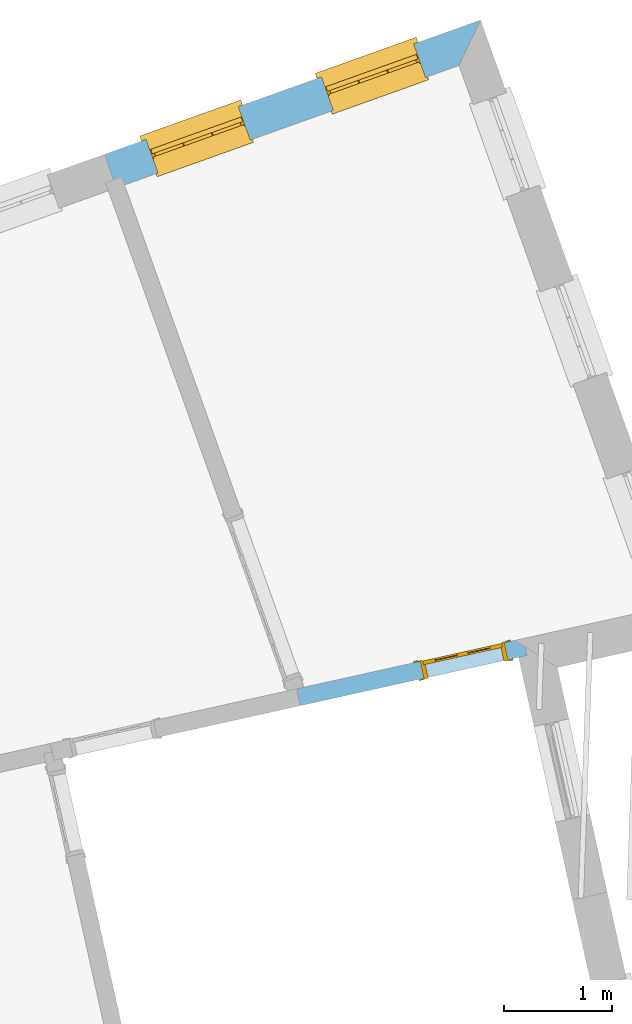
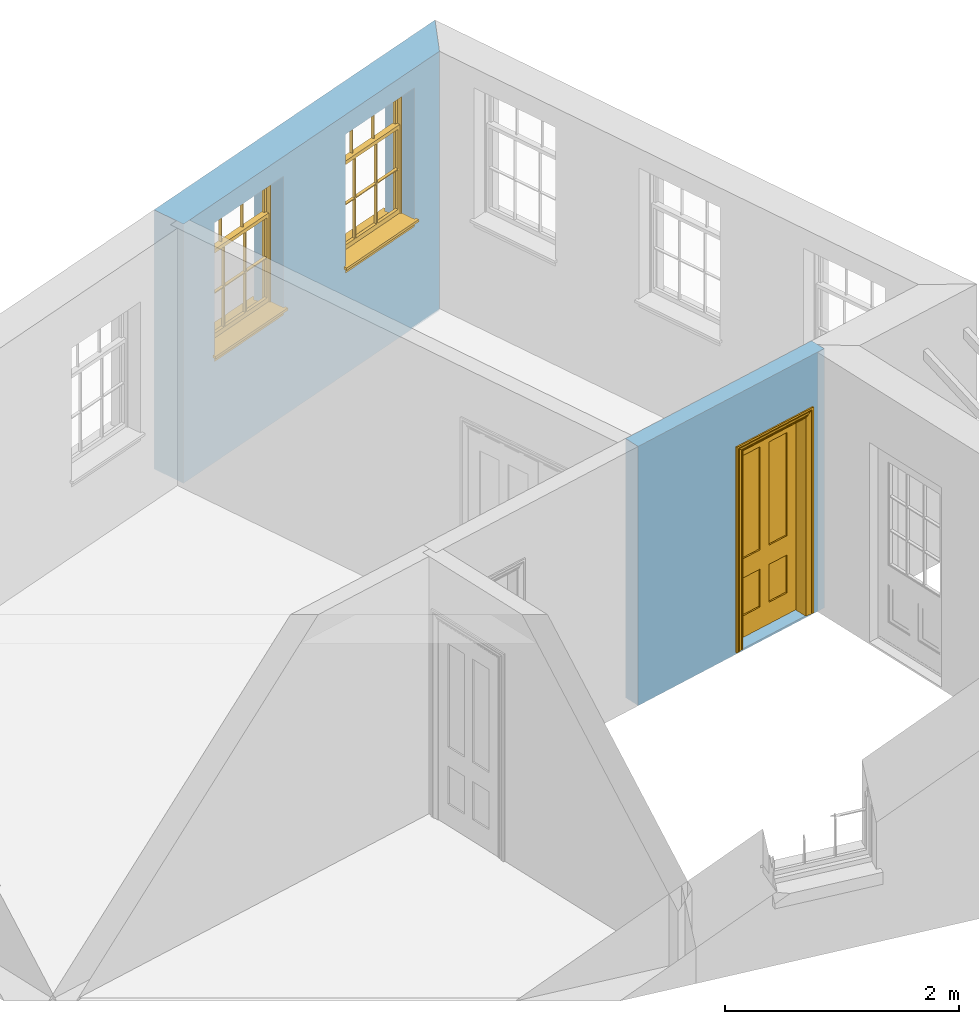
# One storey, part 8 of 11: 2 windows, 1 door, 3 openings, plus 2 elements that do not belong to this part.
"""IFC2X3 building model written with IfcOpenShell, lengths in metres."""

from ifc_helpers import new_model, si_unit, frame, origin, place, context, subcontext, project, spatial, polyline, outline, extrude, faceted_brep, material, layer, layer_set, layer_usage, element, fill, save


model = new_model("IFC2X3")

# Units and contexts
model_context = context("Model", 3, world=origin())
body_context = subcontext(model_context, "Body", "Model", "MODEL_VIEW")
ifc_project = project(units=[si_unit("PLANEANGLEUNIT", "RADIAN"), si_unit("MASSUNIT", "GRAM", prefix="KILO"), si_unit("FORCEUNIT", "NEWTON", prefix="KILO"), si_unit("LENGTHUNIT", "METRE")], contexts=[model_context])

# Site, building, storey
site_placement = place(None, origin())
site = spatial("IfcSite", under=ifc_project, at=site_placement, CompositionType="ELEMENT")
building_placement = place(None, origin())
building = spatial("IfcBuilding", under=site, at=building_placement, Name="Building plot-16", CompositionType="ELEMENT")
storey_placement = place(None, frame((0.0, 0.0, 9.0)))
storey = spatial("IfcBuildingStorey", under=building, at=storey_placement, Name="Floor 2", CompositionType="ELEMENT", Elevation=9.0)

# Wall, openings, windows
ifc_material_1 = material(Name="Masonry")
ifc_layer_1 = layer(ifc_material_1, 0.33, ventilated=False)
ifc_layer_set_1 = layer_set([ifc_layer_1], Name="My Wall")
ifc_layer_usage_1 = layer_usage(ifc_layer_set_1, "AXIS2", "NEGATIVE", 0.08)
wall_1_placement = place(storey_placement, origin())
wall_1 = element("IfcWallStandardCase", 1, at=wall_1_placement, inside=storey, material=ifc_layer_usage_1, Name="exterior", context=body_context, shape_type="SweptSolid", body=[
    extrude(outline(polyline([(95.5770005534573, 40.8505427478087), (95.7767041340643, 41.2723465883469), (92.2893042146699, 40.0260985111248), (92.4003543446355, 39.7153448005522), (95.5770005534573, 40.8505427478087)])), origin(), (0.0, 0.0, 1.0), 2.7),
])
opening_1_placement = place(storey_placement, frame((0.0, 0.0, 1.05)))
opening_1 = element("IfcOpeningElement", 2, at=opening_1_placement, cuts=wall_1, Name="Opening", ObjectType="Opening", context=body_context, shape_type="SweptSolid", body=[
    extrude(outline(polyline([(95.1567529953617, 41.0508024774225), (94.29982609651, 40.7445733311538), (94.4108762264756, 40.4338196205812), (95.2678031253273, 40.74004876685), (95.1567529953617, 41.0508024774225)])), origin(), (0.0, 0.0, 1.0), 1.445),
])
opening_2_placement = place(storey_placement, frame((0.0, 0.0, 1.05)))
opening_2 = element("IfcOpeningElement", 3, at=opening_2_placement, cuts=wall_1, Name="Opening", ObjectType="Opening", context=body_context, shape_type="SweptSolid", body=[
    extrude(outline(polyline([(93.5307627745177, 40.4697428819803), (92.6738358756661, 40.1635137357116), (92.7848860056317, 39.852760025139), (93.6418129044833, 40.1589891714077), (93.5307627745177, 40.4697428819803)])), origin(), (0.0, 0.0, 1.0), 1.445),
])
window_1_placement = place(storey_placement, frame((95.2408818816993, 40.815382999716, 1.05), z_axis=(0.0, 0.0, 1.0), x_axis=(-0.856926898851654, -0.30622914626872, 0.0)))
window_1 = element("IfcWindow", 4, at=window_1_placement, inside=storey, Name="kitchen outside window", OverallHeight=1.445, OverallWidth=0.91, context=body_context, shape_type="Brep", held_by="IfcProductRepresentation", body=[
    faceted_brep([(0.876875, -0.105, 0.999097), (0.876875, -0.105, 1.411875), (0.9, -0.105, 1.435), (0.033125, -0.105, 1.411875), (0.033125, -0.105, 0.999097), (0.01, -0.105, 1.435), (0.033125, -0.135, 1.411875), (0.01, -0.135, 1.435), (0.033125, -0.135, 0.999097), (0.876875, -0.135, 1.411875), (0.876875, -0.135, 0.999097), (0.9, -0.135, 1.435), (0.033125, -0.105, 0.960972), (0.01, -0.105, 0.960972), (0.033125, -0.105, 0.548195), (0.876875, -0.105, 0.960972), (0.876875, -0.105, 0.548195), (0.9, -0.105, 0.960972), (0.876875, -0.105, 0.538195), (0.876875, -0.105, 0.125417), (0.9, -0.105, 0.077167), (0.033125, -0.105, 0.125417), (0.033125, -0.105, 0.538195), (0.01, -0.105, 0.077167), (0.9, -0.135, 0.960972), (0.01, -0.135, 0.960972), (-0.0425, -0.25, 0.01), (-0.0425, -0.3, 0.001667), (0.0, -0.25, 0.01), (0.9525, -0.25, 0.01), (0.91, -0.25, 0.01), (0.9525, -0.3, 0.001667), (-0.02, 0.08, 0.077167), (0.0, 0.08, 0.077167), (-0.02, 0.11, 0.077167), (0.0, -0.06, 0.077167), (0.01, -0.06, 0.077167), (0.91, -0.06, 0.077167), (0.91, 0.08, 0.077167), (0.9, -0.06, 0.077167), (0.93, 0.08, 0.077167), (0.93, 0.11, 0.077167), (0.01, -0.105, 0.999097), (0.01, -0.075, 0.999097), (0.9, -0.105, 0.999097), (0.9, -0.075, 0.999097), (0.876875, -0.075, 0.125417), (0.876875, -0.075, 0.538195), (0.9, -0.075, 0.077167), (0.876875, -0.075, 0.548195), (0.876875, -0.075, 0.960972), (0.033125, -0.075, 0.125417), (0.01, -0.075, 0.077167), (0.033125, -0.075, 0.538195), (0.033125, -0.075, 0.960972), (0.033125, -0.075, 0.548195), (-0.02, 0.08, 0.052167), (-0.02, 0.11, 0.052167), (0.93, 0.11, 0.052167), (0.93, 0.08, 0.052167), (0.91, 0.08, 0.052167), (0.0, 0.08, 0.052167), (0.91, -0.15, 0.026667), (0.0, -0.15, 0.026667), (-0.0425, -0.3, -0.123333), (0.9525, -0.3, -0.123333), (-0.0425, -0.25, -0.123333), (0.9525, -0.25, -0.123333), (0.01, -0.06, 1.435), (0.9, -0.06, 1.435), (0.0, -0.06, 1.445), (0.91, -0.06, 1.445), (0.01, -0.15, 0.077167), (0.9, -0.15, 0.077167), (0.592292, -0.105, 0.125417), (0.592292, -0.075, 0.125417), (0.317708, -0.075, 0.125417), (0.317708, -0.105, 0.125417), (0.592292, -0.105, 0.548195), (0.317708, -0.105, 0.548195), (0.317708, -0.105, 0.538195), (0.592292, -0.105, 0.538195), (0.592292, -0.075, 0.548195), (0.317708, -0.075, 0.548195), (0.602292, -0.075, 0.548195), (0.602292, -0.105, 0.548195), (0.317708, -0.075, 0.538195), (0.307708, -0.075, 0.125417), (0.307708, -0.075, 0.538195), (0.602292, -0.075, 0.538195), (0.602292, -0.075, 0.125417), (0.592292, -0.075, 0.538195), (0.307708, -0.075, 0.548195), (0.317708, -0.075, 0.960972), (0.307708, -0.075, 0.960972), (0.602292, -0.075, 0.960972), (0.592292, -0.075, 0.960972), (0.307708, -0.105, 0.538195), (0.307708, -0.105, 0.125417), (0.307708, -0.105, 0.548195), (0.307708, -0.105, 0.960972), (0.592292, -0.105, 0.960972), (0.317708, -0.105, 0.960972), (0.602292, -0.105, 0.960972), (0.602292, -0.105, 0.538195), (0.602292, -0.105, 0.125417), (0.317708, -0.135, 1.411875), (0.307708, -0.135, 1.411875), (0.307708, -0.135, 0.999097), (0.317708, -0.135, 0.999097), (0.602292, -0.135, 1.411875), (0.592292, -0.135, 1.411875), (0.592292, -0.135, 0.999097), (0.602292, -0.135, 0.999097), (0.317708, -0.105, 0.999097), (0.307708, -0.105, 0.999097), (0.307708, -0.105, 1.411875), (0.317708, -0.105, 1.411875), (0.602292, -0.105, 0.999097), (0.592292, -0.105, 0.999097), (0.592292, -0.105, 1.411875), (0.602292, -0.105, 1.411875), (0.91, -0.15, 1.445), (0.9, -0.15, 1.435), (0.01, -0.15, 1.435), (0.0, -0.15, 1.445), (0.91, -0.25, 0.0), (0.0, -0.25, 0.0), (0.91, 0.08, 0.0), (0.0, 0.08, 0.0)], [[[0, 1, 2]], [[3, 4, 5]], [[6, 7, 8]], [[9, 10, 11]], [[12, 13, 14]], [[15, 16, 17]], [[18, 19, 20]], [[21, 22, 23]], [[24, 15, 17]], [[13, 12, 25]], [[26, 27, 28]], [[29, 30, 31]], [[32, 33, 34]], [[35, 36, 33]], [[37, 38, 39]], [[40, 41, 38]], [[42, 4, 43]], [[44, 45, 0]], [[46, 47, 48]], [[49, 50, 45]], [[51, 52, 53]], [[54, 55, 43]], [[38, 33, 36, 39]], [[41, 34, 33, 38]], [[56, 32, 34, 57]], [[57, 34, 41, 58]], [[58, 41, 40, 59]], [[57, 58, 60, 61]], [[52, 48, 39, 36]], [[62, 63, 28, 30]], [[27, 31, 30, 28]], [[27, 64, 65, 31]], [[66, 67, 65, 64]], [[2, 5, 68, 69]], [[68, 70, 71, 69]], [[20, 23, 72, 73]], [[73, 72, 63, 62]], [[74, 75, 76, 77]], [[78, 79, 80, 81]], [[78, 82, 83, 79]], [[16, 49, 84, 85]], [[86, 76, 87, 88]], [[89, 90, 75, 91]], [[92, 88, 53, 55]], [[82, 91, 86, 83]], [[93, 83, 92, 94]], [[95, 84, 82, 96]], [[89, 84, 49, 47]], [[97, 88, 87, 98]], [[22, 53, 88, 97]], [[81, 91, 75, 74]], [[80, 86, 91, 81]], [[77, 76, 86, 80]], [[99, 92, 55, 14]], [[100, 94, 92, 99]], [[101, 96, 82, 78]], [[79, 83, 93, 102]], [[85, 84, 95, 103]], [[104, 89, 47, 18]], [[105, 90, 89, 104]], [[104, 18, 16, 85]], [[80, 97, 98, 77]], [[104, 81, 74, 105]], [[103, 101, 78, 85]], [[99, 14, 22, 97]], [[102, 100, 99, 79]], [[106, 107, 108, 109]], [[110, 111, 112, 113]], [[114, 115, 116, 117]], [[118, 119, 120, 121]], [[107, 116, 115, 108]], [[111, 120, 119, 112]], [[109, 114, 117, 106]], [[113, 118, 121, 110]], [[85, 78, 81, 104]], [[84, 89, 91, 82]], [[83, 86, 88, 92]], [[79, 99, 97, 80]], [[109, 112, 119, 114]], [[102, 93, 96, 101]], [[106, 117, 120, 111]], [[98, 87, 51, 21]], [[6, 3, 116, 107]], [[110, 121, 1, 9]], [[19, 46, 90, 105]], [[26, 66, 64, 27]], [[29, 31, 65, 67]], [[25, 24, 112, 109]], [[11, 7, 106, 111]], [[75, 48, 52, 76]], [[43, 45, 96, 93]], [[45, 43, 114, 119]], [[5, 2, 120, 117]], [[24, 25, 102, 101]], [[42, 5, 4]], [[2, 44, 0]], [[49, 45, 48, 47]], [[52, 43, 55, 53]], [[14, 13, 23, 22]], [[20, 17, 16, 18]], [[24, 11, 10]], [[25, 8, 7]], [[8, 4, 3, 6]], [[9, 1, 0, 10]], [[15, 50, 49, 16]], [[18, 47, 46, 19]], [[21, 51, 53, 22]], [[14, 55, 54, 12]], [[44, 2, 69, 45]], [[68, 5, 42, 43]], [[36, 35, 70, 68]], [[39, 69, 71, 37]], [[62, 122, 123, 73]], [[63, 72, 124, 125]], [[8, 108, 115, 4]], [[113, 10, 0, 118]], [[94, 100, 12, 54]], [[17, 20, 73, 24]], [[72, 23, 13, 25]], [[52, 36, 68, 43]], [[69, 39, 48, 45]], [[11, 24, 73, 123]], [[7, 124, 72, 25]], [[23, 77, 98]], [[98, 21, 23]], [[105, 74, 20]], [[20, 19, 105]], [[20, 74, 77, 23]], [[113, 112, 24]], [[24, 10, 113]], [[25, 109, 108]], [[108, 8, 25]], [[110, 9, 11]], [[11, 111, 110]], [[7, 6, 107]], [[107, 106, 7]], [[5, 117, 116]], [[116, 3, 5]], [[121, 120, 2]], [[2, 1, 121]], [[11, 123, 124, 7]], [[122, 125, 124, 123]], [[43, 93, 94]], [[94, 54, 43]], [[96, 45, 95]], [[50, 95, 45]], [[15, 103, 95, 50]], [[48, 75, 90]], [[90, 46, 48]], [[87, 76, 52]], [[52, 51, 87]], [[103, 15, 24]], [[24, 101, 103]], [[100, 102, 25]], [[25, 12, 100]], [[115, 114, 43]], [[43, 4, 115]], [[118, 0, 45]], [[45, 119, 118]], [[71, 70, 125, 122]], [[70, 35, 63, 125]], [[122, 62, 37, 71]], [[126, 67, 66, 127]], [[60, 58, 59]], [[38, 60, 59, 40]], [[61, 56, 57]], [[32, 56, 61, 33]], [[61, 60, 128, 129]], [[62, 60, 38, 37]], [[126, 128, 60, 62]], [[33, 61, 63, 35]], [[61, 129, 127, 63]], [[128, 126, 127, 129]], [[28, 127, 66, 26]], [[63, 127, 28]], [[29, 67, 126, 30]], [[30, 126, 62]]]),
])
fill(opening_1, window_1)
window_2_placement = place(storey_placement, frame((93.6148916608553, 40.2343234042738, 1.05), z_axis=(0.0, 0.0, 1.0), x_axis=(-0.856926898851654, -0.30622914626872, 0.0)))
window_2 = element("IfcWindow", 5, at=window_2_placement, inside=storey, Name="kitchen outside window", OverallHeight=1.445, OverallWidth=0.91, context=body_context, shape_type="Brep", held_by="IfcProductRepresentation", body=[
    faceted_brep([(0.876875, -0.105, 0.999097), (0.876875, -0.105, 1.411875), (0.9, -0.105, 1.435), (0.033125, -0.105, 1.411875), (0.033125, -0.105, 0.999097), (0.01, -0.105, 1.435), (0.033125, -0.135, 1.411875), (0.01, -0.135, 1.435), (0.033125, -0.135, 0.999097), (0.876875, -0.135, 1.411875), (0.876875, -0.135, 0.999097), (0.9, -0.135, 1.435), (0.033125, -0.105, 0.960972), (0.01, -0.105, 0.960972), (0.033125, -0.105, 0.548195), (0.876875, -0.105, 0.960972), (0.876875, -0.105, 0.548195), (0.9, -0.105, 0.960972), (0.876875, -0.105, 0.538195), (0.876875, -0.105, 0.125417), (0.9, -0.105, 0.077167), (0.033125, -0.105, 0.125417), (0.033125, -0.105, 0.538195), (0.01, -0.105, 0.077167), (0.9, -0.135, 0.960972), (0.01, -0.135, 0.960972), (-0.0425, -0.25, 0.01), (-0.0425, -0.3, 0.001667), (0.0, -0.25, 0.01), (0.9525, -0.25, 0.01), (0.91, -0.25, 0.01), (0.9525, -0.3, 0.001667), (-0.02, 0.08, 0.077167), (0.0, 0.08, 0.077167), (-0.02, 0.11, 0.077167), (0.0, -0.06, 0.077167), (0.01, -0.06, 0.077167), (0.91, -0.06, 0.077167), (0.91, 0.08, 0.077167), (0.9, -0.06, 0.077167), (0.93, 0.08, 0.077167), (0.93, 0.11, 0.077167), (0.01, -0.105, 0.999097), (0.01, -0.075, 0.999097), (0.9, -0.105, 0.999097), (0.9, -0.075, 0.999097), (0.876875, -0.075, 0.125417), (0.876875, -0.075, 0.538195), (0.9, -0.075, 0.077167), (0.876875, -0.075, 0.548195), (0.876875, -0.075, 0.960972), (0.033125, -0.075, 0.125417), (0.01, -0.075, 0.077167), (0.033125, -0.075, 0.538195), (0.033125, -0.075, 0.960972), (0.033125, -0.075, 0.548195), (-0.02, 0.08, 0.052167), (-0.02, 0.11, 0.052167), (0.93, 0.11, 0.052167), (0.93, 0.08, 0.052167), (0.91, 0.08, 0.052167), (0.0, 0.08, 0.052167), (0.91, -0.15, 0.026667), (0.0, -0.15, 0.026667), (-0.0425, -0.3, -0.123333), (0.9525, -0.3, -0.123333), (-0.0425, -0.25, -0.123333), (0.9525, -0.25, -0.123333), (0.01, -0.06, 1.435), (0.9, -0.06, 1.435), (0.0, -0.06, 1.445), (0.91, -0.06, 1.445), (0.01, -0.15, 0.077167), (0.9, -0.15, 0.077167), (0.592292, -0.105, 0.125417), (0.592292, -0.075, 0.125417), (0.317708, -0.075, 0.125417), (0.317708, -0.105, 0.125417), (0.592292, -0.105, 0.548195), (0.317708, -0.105, 0.548195), (0.317708, -0.105, 0.538195), (0.592292, -0.105, 0.538195), (0.592292, -0.075, 0.548195), (0.317708, -0.075, 0.548195), (0.602292, -0.075, 0.548195), (0.602292, -0.105, 0.548195), (0.317708, -0.075, 0.538195), (0.307708, -0.075, 0.125417), (0.307708, -0.075, 0.538195), (0.602292, -0.075, 0.538195), (0.602292, -0.075, 0.125417), (0.592292, -0.075, 0.538195), (0.307708, -0.075, 0.548195), (0.317708, -0.075, 0.960972), (0.307708, -0.075, 0.960972), (0.602292, -0.075, 0.960972), (0.592292, -0.075, 0.960972), (0.307708, -0.105, 0.538195), (0.307708, -0.105, 0.125417), (0.307708, -0.105, 0.548195), (0.307708, -0.105, 0.960972), (0.592292, -0.105, 0.960972), (0.317708, -0.105, 0.960972), (0.602292, -0.105, 0.960972), (0.602292, -0.105, 0.538195), (0.602292, -0.105, 0.125417), (0.317708, -0.135, 1.411875), (0.307708, -0.135, 1.411875), (0.307708, -0.135, 0.999097), (0.317708, -0.135, 0.999097), (0.602292, -0.135, 1.411875), (0.592292, -0.135, 1.411875), (0.592292, -0.135, 0.999097), (0.602292, -0.135, 0.999097), (0.317708, -0.105, 0.999097), (0.307708, -0.105, 0.999097), (0.307708, -0.105, 1.411875), (0.317708, -0.105, 1.411875), (0.602292, -0.105, 0.999097), (0.592292, -0.105, 0.999097), (0.592292, -0.105, 1.411875), (0.602292, -0.105, 1.411875), (0.91, -0.15, 1.445), (0.9, -0.15, 1.435), (0.01, -0.15, 1.435), (0.0, -0.15, 1.445), (0.91, -0.25, 0.0), (0.0, -0.25, 0.0), (0.91, 0.08, 0.0), (0.0, 0.08, 0.0)], [[[0, 1, 2]], [[3, 4, 5]], [[6, 7, 8]], [[9, 10, 11]], [[12, 13, 14]], [[15, 16, 17]], [[18, 19, 20]], [[21, 22, 23]], [[24, 15, 17]], [[13, 12, 25]], [[26, 27, 28]], [[29, 30, 31]], [[32, 33, 34]], [[35, 36, 33]], [[37, 38, 39]], [[40, 41, 38]], [[42, 4, 43]], [[44, 45, 0]], [[46, 47, 48]], [[49, 50, 45]], [[51, 52, 53]], [[54, 55, 43]], [[38, 33, 36, 39]], [[41, 34, 33, 38]], [[56, 32, 34, 57]], [[57, 34, 41, 58]], [[58, 41, 40, 59]], [[57, 58, 60, 61]], [[52, 48, 39, 36]], [[62, 63, 28, 30]], [[27, 31, 30, 28]], [[27, 64, 65, 31]], [[66, 67, 65, 64]], [[2, 5, 68, 69]], [[68, 70, 71, 69]], [[20, 23, 72, 73]], [[73, 72, 63, 62]], [[74, 75, 76, 77]], [[78, 79, 80, 81]], [[78, 82, 83, 79]], [[16, 49, 84, 85]], [[86, 76, 87, 88]], [[89, 90, 75, 91]], [[92, 88, 53, 55]], [[82, 91, 86, 83]], [[93, 83, 92, 94]], [[95, 84, 82, 96]], [[89, 84, 49, 47]], [[97, 88, 87, 98]], [[22, 53, 88, 97]], [[81, 91, 75, 74]], [[80, 86, 91, 81]], [[77, 76, 86, 80]], [[99, 92, 55, 14]], [[100, 94, 92, 99]], [[101, 96, 82, 78]], [[79, 83, 93, 102]], [[85, 84, 95, 103]], [[104, 89, 47, 18]], [[105, 90, 89, 104]], [[104, 18, 16, 85]], [[80, 97, 98, 77]], [[104, 81, 74, 105]], [[103, 101, 78, 85]], [[99, 14, 22, 97]], [[102, 100, 99, 79]], [[106, 107, 108, 109]], [[110, 111, 112, 113]], [[114, 115, 116, 117]], [[118, 119, 120, 121]], [[107, 116, 115, 108]], [[111, 120, 119, 112]], [[109, 114, 117, 106]], [[113, 118, 121, 110]], [[85, 78, 81, 104]], [[84, 89, 91, 82]], [[83, 86, 88, 92]], [[79, 99, 97, 80]], [[109, 112, 119, 114]], [[102, 93, 96, 101]], [[106, 117, 120, 111]], [[98, 87, 51, 21]], [[6, 3, 116, 107]], [[110, 121, 1, 9]], [[19, 46, 90, 105]], [[26, 66, 64, 27]], [[29, 31, 65, 67]], [[25, 24, 112, 109]], [[11, 7, 106, 111]], [[75, 48, 52, 76]], [[43, 45, 96, 93]], [[45, 43, 114, 119]], [[5, 2, 120, 117]], [[24, 25, 102, 101]], [[42, 5, 4]], [[2, 44, 0]], [[49, 45, 48, 47]], [[52, 43, 55, 53]], [[14, 13, 23, 22]], [[20, 17, 16, 18]], [[24, 11, 10]], [[25, 8, 7]], [[8, 4, 3, 6]], [[9, 1, 0, 10]], [[15, 50, 49, 16]], [[18, 47, 46, 19]], [[21, 51, 53, 22]], [[14, 55, 54, 12]], [[44, 2, 69, 45]], [[68, 5, 42, 43]], [[36, 35, 70, 68]], [[39, 69, 71, 37]], [[62, 122, 123, 73]], [[63, 72, 124, 125]], [[8, 108, 115, 4]], [[113, 10, 0, 118]], [[94, 100, 12, 54]], [[17, 20, 73, 24]], [[72, 23, 13, 25]], [[52, 36, 68, 43]], [[69, 39, 48, 45]], [[11, 24, 73, 123]], [[7, 124, 72, 25]], [[23, 77, 98]], [[98, 21, 23]], [[105, 74, 20]], [[20, 19, 105]], [[20, 74, 77, 23]], [[113, 112, 24]], [[24, 10, 113]], [[25, 109, 108]], [[108, 8, 25]], [[110, 9, 11]], [[11, 111, 110]], [[7, 6, 107]], [[107, 106, 7]], [[5, 117, 116]], [[116, 3, 5]], [[121, 120, 2]], [[2, 1, 121]], [[11, 123, 124, 7]], [[122, 125, 124, 123]], [[43, 93, 94]], [[94, 54, 43]], [[96, 45, 95]], [[50, 95, 45]], [[15, 103, 95, 50]], [[48, 75, 90]], [[90, 46, 48]], [[87, 76, 52]], [[52, 51, 87]], [[103, 15, 24]], [[24, 101, 103]], [[100, 102, 25]], [[25, 12, 100]], [[115, 114, 43]], [[43, 4, 115]], [[118, 0, 45]], [[45, 119, 118]], [[71, 70, 125, 122]], [[70, 35, 63, 125]], [[122, 62, 37, 71]], [[126, 67, 66, 127]], [[60, 58, 59]], [[38, 60, 59, 40]], [[61, 56, 57]], [[32, 56, 61, 33]], [[61, 60, 128, 129]], [[62, 60, 38, 37]], [[126, 128, 60, 62]], [[33, 61, 63, 35]], [[61, 129, 127, 63]], [[128, 126, 127, 129]], [[28, 127, 66, 26]], [[63, 127, 28]], [[29, 67, 126, 30]], [[30, 126, 62]]]),
])
fill(opening_2, window_2)

# Wall, opening, door
ifc_material_2 = material(Name="Masonry")
ifc_layer_2 = layer(ifc_material_2, 0.16, ventilated=False)
ifc_layer_set_2 = layer_set([ifc_layer_2], Name="My Wall")
ifc_layer_usage_2 = layer_usage(ifc_layer_set_2, "AXIS2", "NEGATIVE", 0.08)
wall_2_placement = place(storey_placement, origin())
wall_2 = element("IfcWallStandardCase", 6, at=wall_2_placement, inside=storey, material=ifc_layer_usage_2, Name="interior", context=body_context, shape_type="SweptSolid", body=[
    extrude(outline(polyline([(94.0715489961098, 35.0684438743723), (94.1061893742812, 34.9122387393731), (96.2085172547257, 35.378455376997), (96.1738768765543, 35.5346605119962), (94.0715489961098, 35.0684438743723)])), origin(), (0.0, 0.0, 1.0), 2.7),
])
opening_3_placement = place(storey_placement, frame((0.0, 0.0, 0.0199999999999996)))
opening_3 = element("IfcOpeningElement", 7, at=opening_3_placement, cuts=wall_2, Name="Opening", ObjectType="Opening", context=body_context, shape_type="SweptSolid", body=[
    extrude(outline(polyline([(95.2517608028552, 35.1662830606969), (96.0327864778515, 35.3394849515541), (95.9981460996801, 35.4956900865534), (95.2171204246837, 35.3224881956962), (95.2517608028552, 35.1662830606969)])), origin(), (0.0, 0.0, 1.0), 2.1),
])
door_placement = place(storey_placement, frame((95.2344406137695, 35.2443856281966, 0.0199999999999996), z_axis=(0.0, 0.0, 1.0), x_axis=(0.781025674996357, 0.173201890857172, 0.0)))
door = element("IfcDoor", 8, at=door_placement, inside=storey, Name="kitchen inside door", OverallHeight=2.1, OverallWidth=0.8, context=body_context, shape_type="Brep", held_by="IfcProductRepresentation", body=[
    faceted_brep([(0.773, 0.08, 1.895), (0.66, 0.08, 1.895), (0.66, 0.08, 2.073), (0.773, 0.08, 2.073), (0.773, 0.08, 0.82), (0.66, 0.08, 0.82), (0.45, 0.08, 1.895), (0.45, 0.08, 2.073), (0.773, 0.08, 0.62), (0.66, 0.08, 0.62), (0.66, 0.065, 0.82), (0.66, 0.065, 1.895), (0.45, 0.065, 1.895), (0.35, 0.08, 1.895), (0.35, 0.08, 2.073), (0.773, 0.08, 0.225), (0.66, 0.08, 0.225), (0.45, 0.08, 0.62), (0.45, 0.08, 0.82), (0.45, 0.065, 0.82), (0.35, 0.08, 0.82), (0.14, 0.08, 2.073), (0.14, 0.08, 1.895), (0.773, 0.08, 0.0), (0.66, 0.08, 0.0), (0.66, 0.065, 0.225), (0.66, 0.065, 0.62), (0.45, 0.065, 0.62), (0.35, 0.08, 0.62), (0.35, 0.065, 0.82), (0.35, 0.065, 1.895), (0.14, 0.065, 1.895), (0.027, 0.08, 2.073), (0.027, 0.08, 1.895), (0.773, 0.042, 0.0), (0.66, 0.042, 0.0), (0.45, 0.08, 0.0), (0.45, 0.08, 0.225), (0.45, 0.065, 0.225), (0.35, 0.08, 0.225), (0.14, 0.08, 0.82), (0.14, 0.08, 0.62), (0.14, 0.065, 0.82), (0.027, 0.08, 0.82), (0.773, 0.042, 0.225), (0.66, 0.042, 0.225), (0.45, 0.042, 0.0), (0.35, 0.08, 0.0), (0.35, 0.065, 0.225), (0.35, 0.065, 0.62), (0.14, 0.065, 0.62), (0.027, 0.08, 0.62), (0.773, 0.042, 0.62), (0.66, 0.042, 0.62), (0.45, 0.042, 0.225), (0.35, 0.042, 0.0), (0.14, 0.08, 0.225), (0.14, 0.08, 0.0), (0.14, 0.065, 0.225), (0.027, 0.08, 0.225), (0.773, 0.042, 0.82), (0.66, 0.042, 0.82), (0.66, 0.057, 0.62), (0.66, 0.057, 0.225), (0.45, 0.057, 0.225), (0.35, 0.042, 0.225), (0.14, 0.042, 0.0), (0.027, 0.08, 0.0), (0.773, 0.042, 1.895), (0.66, 0.042, 1.895), (0.45, 0.042, 0.62), (0.45, 0.042, 0.82), (0.45, 0.057, 0.62), (0.35, 0.042, 0.62), (0.14, 0.042, 0.225), (0.027, 0.042, 0.0), (0.773, 0.042, 2.073), (0.66, 0.042, 2.073), (0.66, 0.057, 1.895), (0.66, 0.057, 0.82), (0.45, 0.057, 0.82), (0.35, 0.042, 0.82), (0.35, 0.057, 0.62), (0.35, 0.057, 0.225), (0.14, 0.057, 0.225), (0.027, 0.042, 0.225), (0.45, 0.042, 1.895), (0.45, 0.042, 2.073), (0.45, 0.057, 1.895), (0.35, 0.042, 1.895), (0.14, 0.042, 0.82), (0.14, 0.042, 0.62), (0.14, 0.057, 0.62), (0.027, 0.042, 0.62), (0.35, 0.042, 2.073), (0.35, 0.057, 1.895), (0.35, 0.057, 0.82), (0.14, 0.057, 0.82), (0.027, 0.042, 0.82), (0.14, 0.042, 2.073), (0.14, 0.042, 1.895), (0.14, 0.057, 1.895), (0.027, 0.042, 1.895), (0.027, 0.042, 2.073), (0.02, 0.085, 0.0), (0.005, 0.09, 0.0), (0.005, 0.09, 2.095), (0.02, 0.085, 2.08), (0.02, 0.08, 0.0), (0.0, 0.085, 0.0), (0.0, 0.085, 2.1), (0.795, 0.09, 2.095), (0.78, 0.085, 2.08), (0.02, 0.08, 2.08), (0.0, 0.08, 0.0), (-0.032, 0.095, 0.0), (-0.032, 0.095, 2.132), (0.8, 0.085, 2.1), (0.795, 0.09, 0.0), (0.78, 0.085, 0.0), (0.78, 0.08, 2.08), (0.04, 0.04, 0.0), (0.025, 0.04, 0.0), (0.025, 0.04, 2.075), (0.04, 0.04, 2.06), (-0.04, 0.09, 0.0), (-0.04, 0.09, 2.14), (0.832, 0.095, 2.132), (0.8, 0.085, 0.0), (0.78, 0.08, 0.0), (0.8, 0.08, 0.0), (0.86, 0.08, 0.0), (0.86, 0.08, 2.16), (0.8, 0.08, 2.1), (-0.06, 0.08, 2.16), (0.0, 0.08, 2.1), (-0.06, 0.08, 0.0), (-0.04, 0.095, 0.0), (-0.04, 0.095, 2.14), (0.84, 0.09, 2.14), (0.832, 0.095, 0.0), (0.84, 0.09, 0.0), (0.86, 0.095, 0.0), (0.86, 0.095, 2.16), (-0.06, 0.095, 2.16), (-0.06, 0.095, 0.0), (0.84, 0.095, 0.0), (0.84, 0.095, 2.14), (-0.025, -0.095, 0.0), (-0.025, -0.09, 0.0), (-0.025, -0.09, 2.125), (-0.025, -0.095, 2.125), (-0.017, -0.095, 0.0), (-0.017, -0.095, 2.117), (0.825, -0.09, 2.125), (0.825, -0.095, 2.125), (0.825, -0.095, 0.0), (0.845, -0.095, 0.0), (-0.045, -0.095, 2.145), (-0.045, -0.095, 0.0), (0.845, -0.095, 2.145), (0.015, -0.085, 0.0), (0.015, -0.085, 2.085), (0.817, -0.095, 2.117), (0.825, -0.09, 0.0), (0.845, -0.08, 0.0), (0.845, -0.08, 2.145), (-0.045, -0.08, 2.145), (-0.045, -0.08, 0.0), (0.02, -0.09, 0.0), (0.02, -0.09, 2.08), (0.785, -0.085, 2.085), (0.817, -0.095, 0.0), (0.8, -0.08, 0.0), (0.8, -0.08, 2.1), (0.0, -0.08, 2.1), (0.0, -0.08, 0.0), (0.035, -0.085, 0.0), (0.035, -0.085, 2.065), (0.78, -0.09, 2.08), (0.785, -0.085, 0.0), (0.775, 0.04, 2.075), (0.76, 0.04, 2.06), (0.035, -0.08, 2.065), (0.035, -0.08, 0.0), (0.765, -0.085, 2.065), (0.78, -0.09, 0.0), (0.765, -0.08, 0.0), (0.765, -0.08, 2.065), (0.765, -0.085, 0.0), (0.04, -0.08, 2.06), (0.04, -0.08, 0.0), (0.76, -0.08, 2.06), (0.76, -0.08, 0.0), (0.76, 0.04, 0.0), (0.775, 0.04, 0.0), (0.025, 0.08, 0.0), (0.025, 0.08, 2.075), (0.775, 0.08, 0.0), (0.775, 0.08, 2.075)], [[[0, 1, 2, 3]], [[1, 0, 4, 5]], [[1, 6, 7, 2]], [[8, 9, 5, 4]], [[1, 5, 10, 11]], [[6, 1, 11, 12]], [[6, 13, 14, 7]], [[15, 16, 9, 8]], [[9, 17, 18, 5]], [[5, 18, 19, 10]], [[10, 19, 12, 11]], [[18, 6, 12, 19]], [[18, 20, 13, 6]], [[21, 14, 13, 22]], [[23, 24, 16, 15]], [[9, 16, 25, 26]], [[17, 9, 26, 27]], [[17, 28, 20, 18]], [[13, 20, 29, 30]], [[22, 13, 30, 31]], [[32, 21, 22, 33]], [[34, 35, 24, 23]], [[24, 36, 37, 16]], [[16, 37, 38, 25]], [[25, 38, 27, 26]], [[37, 17, 27, 38]], [[37, 39, 28, 17]], [[40, 20, 28, 41]], [[20, 40, 42, 29]], [[31, 30, 29, 42]], [[40, 22, 31, 42]], [[33, 22, 40, 43]], [[35, 34, 44, 45]], [[35, 46, 36, 24]], [[36, 47, 39, 37]], [[28, 39, 48, 49]], [[41, 28, 49, 50]], [[43, 40, 41, 51]], [[45, 44, 52, 53]], [[46, 35, 45, 54]], [[46, 55, 47, 36]], [[56, 39, 47, 57]], [[39, 56, 58, 48]], [[50, 49, 48, 58]], [[56, 41, 50, 58]], [[51, 41, 56, 59]], [[53, 52, 60, 61]], [[45, 53, 62, 63]], [[54, 45, 63, 64]], [[55, 46, 54, 65]], [[55, 66, 57, 47]], [[59, 56, 57, 67]], [[61, 60, 68, 69]], [[70, 53, 61, 71]], [[53, 70, 72, 62]], [[72, 64, 63, 62]], [[70, 54, 64, 72]], [[65, 54, 70, 73]], [[65, 74, 66, 55]], [[67, 57, 66, 75]], [[69, 68, 76, 77]], [[61, 69, 78, 79]], [[71, 61, 79, 80]], [[73, 70, 71, 81]], [[65, 73, 82, 83]], [[74, 65, 83, 84]], [[74, 85, 75, 66]], [[86, 69, 77, 87]], [[69, 86, 88, 78]], [[88, 80, 79, 78]], [[86, 71, 80, 88]], [[81, 71, 86, 89]], [[73, 81, 90, 91]], [[73, 91, 92, 82]], [[83, 82, 92, 84]], [[91, 74, 84, 92]], [[91, 93, 85, 74]], [[89, 86, 87, 94]], [[81, 89, 95, 96]], [[90, 81, 96, 97]], [[90, 98, 93, 91]], [[94, 99, 100, 89]], [[89, 100, 101, 95]], [[101, 97, 96, 95]], [[100, 90, 97, 101]], [[100, 102, 98, 90]], [[99, 103, 102, 100]], [[32, 103, 99, 21]], [[102, 103, 32, 33]], [[98, 102, 33, 43]], [[21, 99, 94, 14]], [[94, 87, 7, 14]], [[7, 87, 77, 2]], [[76, 3, 2, 77]], [[43, 51, 93, 98]], [[51, 59, 85, 93]], [[67, 75, 85, 59]], [[34, 23, 15, 44]], [[44, 15, 8, 52]], [[52, 8, 4, 60]], [[0, 68, 60, 4]], [[0, 3, 76, 68]], [[104, 105, 106, 107]], [[104, 108, 109, 105]], [[105, 109, 110, 106]], [[107, 106, 111, 112]], [[107, 113, 108, 104]], [[114, 109, 108]], [[109, 115, 116, 110]], [[106, 110, 117, 111]], [[112, 111, 118, 119]], [[113, 107, 112, 120]], [[121, 122, 123, 124]], [[115, 109, 114, 125]], [[115, 125, 126, 116]], [[110, 116, 127, 117]], [[111, 117, 128, 118]], [[118, 128, 129, 119]], [[120, 112, 119, 129]], [[130, 129, 128]], [[130, 131, 132, 133]], [[133, 132, 134, 135]], [[135, 134, 136, 114]], [[136, 125, 114]], [[125, 137, 138, 126]], [[116, 126, 139, 127]], [[117, 127, 140, 128]], [[141, 130, 128, 140]], [[131, 130, 141]], [[131, 142, 143, 132]], [[132, 143, 144, 134]], [[134, 144, 145, 136]], [[137, 125, 136, 145]], [[143, 142, 146]], [[143, 146, 147]], [[137, 145, 144]], [[143, 147, 138]], [[138, 137, 144]], [[143, 138, 144]], [[126, 138, 147, 139]], [[127, 139, 141, 140]], [[142, 131, 141, 146]], [[139, 147, 146, 141]], [[148, 149, 150, 151]], [[149, 152, 153, 150]], [[151, 150, 154, 155]], [[155, 156, 157]], [[158, 159, 148]], [[158, 148, 151]], [[155, 157, 160]], [[158, 151, 155]], [[155, 160, 158]], [[152, 161, 162, 153]], [[150, 153, 163, 154]], [[155, 154, 164, 156]], [[156, 164, 165, 157]], [[157, 165, 166, 160]], [[160, 166, 167, 158]], [[158, 167, 168, 159]], [[161, 169, 170, 162]], [[153, 162, 171, 163]], [[154, 163, 172, 164]], [[165, 164, 173]], [[165, 173, 174, 166]], [[166, 174, 175, 167]], [[167, 175, 176, 168]], [[169, 177, 178, 170]], [[162, 170, 179, 171]], [[163, 171, 180, 172]], [[172, 180, 173, 164]], [[124, 123, 181, 182]], [[183, 178, 177, 184]], [[170, 178, 185, 179]], [[171, 179, 186, 180]], [[187, 173, 180]], [[185, 188, 187, 189]], [[188, 185, 178, 183]], [[179, 185, 189, 186]], [[189, 187, 180, 186]], [[190, 183, 184, 191]], [[192, 188, 183, 190]], [[191, 184, 122, 121]], [[124, 190, 191, 121]], [[193, 187, 188, 192]], [[182, 192, 190, 124]], [[184, 176, 122]], [[194, 195, 187, 193]], [[192, 182, 194, 193]], [[161, 176, 184]], [[114, 108, 122, 176]], [[173, 187, 195]], [[152, 149, 176, 161]], [[169, 161, 184, 177]], [[196, 122, 108]], [[176, 175, 135, 114]], [[173, 195, 129, 130]], [[176, 149, 168]], [[123, 122, 196, 197]], [[196, 108, 113, 197]], [[175, 174, 133, 135]], [[198, 129, 195]], [[133, 174, 173, 130]], [[159, 168, 149, 148]], [[181, 123, 197, 199]], [[197, 113, 120, 199]], [[199, 120, 129, 198]], [[195, 181, 199, 198]], [[195, 194, 182, 181]]]),
])
fill(opening_3, door)

save(model, "model.ifc")
